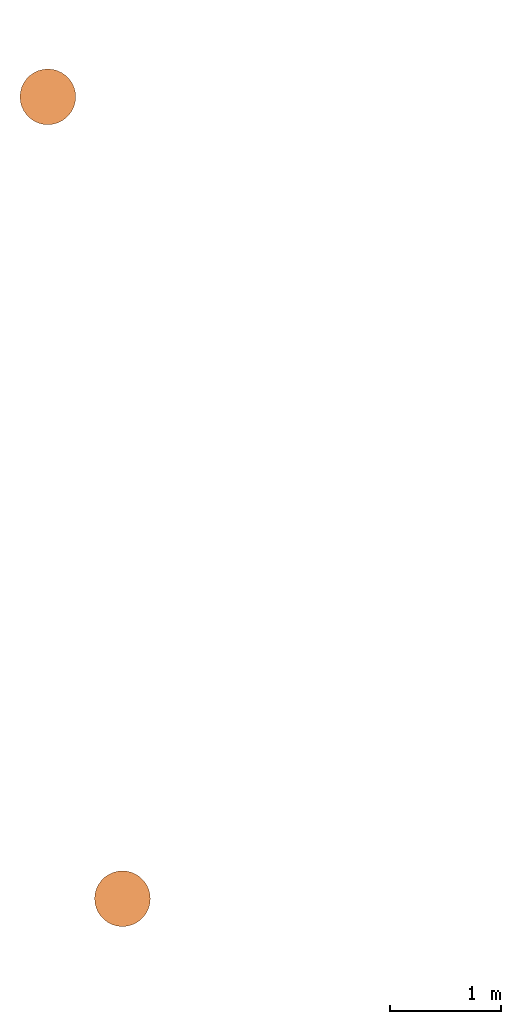
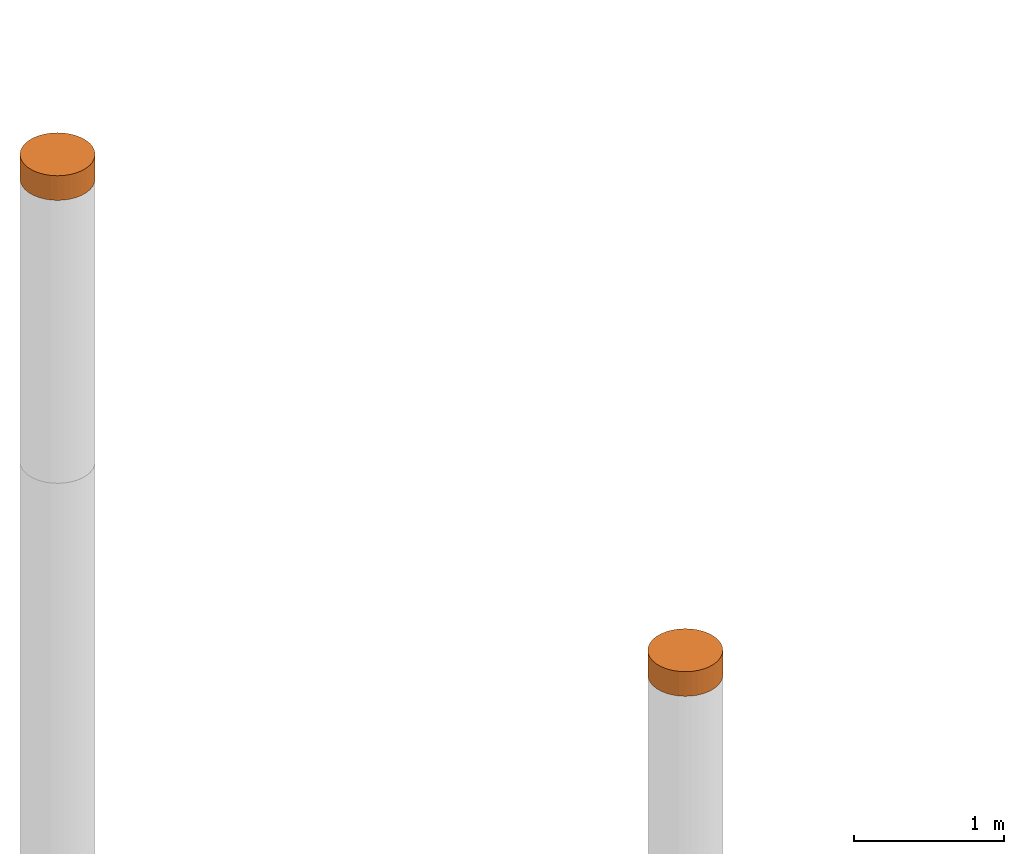
# One storey, part 6 of 8: 2 proxies.
"""IFC4 building model written with IfcOpenShell, lengths in metres."""

from ifc_helpers import new_model, entity, si_unit, converted_unit, frame, origin, place, context, subcontext, project, spatial, faceted_brep, material, element, save


model = new_model("IFC4")

# Units and contexts
model_context = context("Model", 3, precision=1e-05, world=origin())
body_context = subcontext(model_context, "Body", "Model", "MODEL_VIEW")
ifc_project = project(units=[si_unit("LENGTHUNIT", "METRE"), si_unit("AREAUNIT", "SQUARE_METRE"), si_unit("VOLUMEUNIT", "CUBIC_METRE"), converted_unit("PLANEANGLEUNIT", "DEGREE", entity("IfcPlaneAngleMeasure", 0.0174532925199433), si_unit("PLANEANGLEUNIT", "RADIAN"), dimensions=[0, 0, 0, 0, 0, 0, 0])], contexts=[model_context])

# Site, building, storey
site_placement = place(None, origin())
site = spatial("IfcSite", under=ifc_project, at=site_placement, CompositionType="ELEMENT")
building_placement = place(site_placement, origin())
building = spatial("IfcBuilding", under=site, at=building_placement, Name="Demo", CompositionType="ELEMENT")
storey_placement = place(building_placement, origin())
storey = spatial("IfcBuildingStorey", under=building, at=storey_placement, Name="Boden", CompositionType="ELEMENT", Elevation=0.0)

# Proxies
ifc_material_1 = material()
proxy_1_placement = place(storey_placement, frame((2.57, 5.87, -0.1)))
element("IfcBuildingElementProxy", 1, at=proxy_1_placement, inside=storey, material=ifc_material_1, Name="KB-01", PredefinedType="USERDEFINED", context=body_context, shape_type="Brep", body=[
    faceted_brep([(0.4962019382530516, 0.2934120444167338, 0.2), (0.5, 0.25, 0.2), (0.496201938253052, 0.2065879555832671, 0.2), (0.4849231551964772, 0.1644949641685826, 0.2), (0.4665063509461097, 0.125, 0.2), (0.4415111107797448, 0.08930309757836494, 0.2), (0.4106969024216351, 0.05848888922025526, 0.2), (0.375, 0.0334936490538903, 0.2), (0.3355050358314174, 0.01507684480352327, 0.2), (0.2934120444167325, 0.003798061746948406, 0.2), (0.25, 0.0, 0.2), (0.2065879555832676, 0.003798061746948406, 0.2), (0.164494964168583, 0.01507684480352327, 0.2), (0.125, 0.0334936490538903, 0.2), (0.0893030975783654, 0.05848888922025526, 0.2), (0.05848888922025572, 0.08930309757836494, 0.2), (0.0334936490538903, 0.125, 0.2), (0.01507684480352327, 0.1644949641685826, 0.2), (0.003798061746947951, 0.2065879555832671, 0.2), (0.0, 0.25, 0.2), (0.003798061746947951, 0.293412044416732, 0.2), (0.01507684480352282, 0.3355050358314166, 0.2), (0.03349364905388984, 0.375, 0.2), (0.05848888922025526, 0.4106969024216342, 0.2), (0.08930309757836494, 0.4415111107797439, 0.2), (0.1249999999999995, 0.4665063509461097, 0.2), (0.1644949641685821, 0.4849231551964767, 0.2), (0.2065879555832667, 0.4962019382530516, 0.2), (0.2499999999999991, 0.5, 0.2), (0.293412044416732, 0.4962019382530525, 0.2), (0.3355050358314166, 0.4849231551964777, 0.2), (0.3749999999999991, 0.4665063509461097, 0.2), (0.4106969024216342, 0.4415111107797448, 0.2), (0.4415111107797439, 0.410696902421636, 0.2), (0.4665063509461093, 0.3750000000000009, 0.2), (0.4849231551964767, 0.3355050358314184, 0.2), (0.5, 0.25, 0.0), (0.4962019382530516, 0.2934120444167338, 0.0), (0.4849231551964767, 0.3355050358314184, 0.0), (0.4665063509461093, 0.3750000000000009, 0.0), (0.4415111107797439, 0.410696902421636, 0.0), (0.4106969024216342, 0.4415111107797448, 0.0), (0.3749999999999991, 0.4665063509461097, 0.0), (0.3355050358314166, 0.4849231551964777, 0.0), (0.293412044416732, 0.4962019382530525, 0.0), (0.2499999999999991, 0.5, 0.0), (0.2065879555832667, 0.4962019382530516, 0.0), (0.1644949641685821, 0.4849231551964767, 0.0), (0.1249999999999995, 0.4665063509461097, 0.0), (0.08930309757836494, 0.4415111107797439, 0.0), (0.05848888922025526, 0.4106969024216342, 0.0), (0.03349364905388984, 0.3749999999999991, 0.0), (0.01507684480352282, 0.3355050358314166, 0.0), (0.003798061746947951, 0.293412044416732, 0.0), (0.0, 0.25, 0.0), (0.003798061746947951, 0.2065879555832671, 0.0), (0.01507684480352327, 0.1644949641685826, 0.0), (0.0334936490538903, 0.125, 0.0), (0.05848888922025572, 0.08930309757836494, 0.0), (0.0893030975783654, 0.05848888922025526, 0.0), (0.125, 0.0334936490538903, 0.0), (0.164494964168583, 0.01507684480352327, 0.0), (0.2065879555832676, 0.003798061746948406, 0.0), (0.25, 0.0, 0.0), (0.2934120444167325, 0.003798061746948406, 0.0), (0.3355050358314174, 0.01507684480352327, 0.0), (0.375, 0.0334936490538903, 0.0), (0.4106969024216351, 0.05848888922025526, 0.0), (0.4415111107797448, 0.08930309757836494, 0.0), (0.4665063509461097, 0.125, 0.0), (0.4849231551964772, 0.1644949641685826, 0.0), (0.496201938253052, 0.2065879555832671, 0.0), (0.5, 0.25, 0.2), (0.4962019382530516, 0.2934120444167338, 0.2), (0.4962019382530516, 0.2934120444167338, 0.0), (0.5, 0.25, 0.0), (0.496201938253052, 0.2065879555832671, 0.2), (0.5, 0.25, 0.2), (0.5, 0.25, 0.0), (0.496201938253052, 0.2065879555832671, 0.0), (0.4849231551964772, 0.1644949641685826, 0.2), (0.496201938253052, 0.2065879555832671, 0.2), (0.496201938253052, 0.2065879555832671, 0.0), (0.4849231551964772, 0.1644949641685826, 0.0), (0.4665063509461097, 0.125, 0.2), (0.4849231551964772, 0.1644949641685826, 0.2), (0.4849231551964772, 0.1644949641685826, 0.0), (0.4665063509461097, 0.125, 0.0), (0.4415111107797448, 0.08930309757836494, 0.2), (0.4665063509461097, 0.125, 0.2), (0.4665063509461097, 0.125, 0.0), (0.4415111107797448, 0.08930309757836494, 0.0), (0.4106969024216351, 0.05848888922025526, 0.2), (0.4415111107797448, 0.08930309757836494, 0.2), (0.4415111107797448, 0.08930309757836494, 0.0), (0.4106969024216351, 0.05848888922025526, 0.0), (0.375, 0.0334936490538903, 0.2), (0.4106969024216351, 0.05848888922025526, 0.2), (0.4106969024216351, 0.05848888922025526, 0.0), (0.375, 0.0334936490538903, 0.0), (0.3355050358314174, 0.01507684480352327, 0.2), (0.375, 0.0334936490538903, 0.2), (0.375, 0.0334936490538903, 0.0), (0.3355050358314174, 0.01507684480352327, 0.0), (0.2934120444167325, 0.003798061746948406, 0.2), (0.3355050358314174, 0.01507684480352327, 0.2), (0.3355050358314174, 0.01507684480352327, 0.0), (0.2934120444167325, 0.003798061746948406, 0.0), (0.25, 0.0, 0.2), (0.2934120444167325, 0.003798061746948406, 0.2), (0.2934120444167325, 0.003798061746948406, 0.0), (0.25, 0.0, 0.0), (0.2065879555832676, 0.003798061746948406, 0.2), (0.25, 0.0, 0.2), (0.25, 0.0, 0.0), (0.2065879555832676, 0.003798061746948406, 0.0), (0.164494964168583, 0.01507684480352327, 0.2), (0.2065879555832676, 0.003798061746948406, 0.2), (0.2065879555832676, 0.003798061746948406, 0.0), (0.164494964168583, 0.01507684480352327, 0.0), (0.125, 0.0334936490538903, 0.2), (0.164494964168583, 0.01507684480352327, 0.2), (0.164494964168583, 0.01507684480352327, 0.0), (0.125, 0.0334936490538903, 0.0), (0.0893030975783654, 0.05848888922025526, 0.2), (0.125, 0.0334936490538903, 0.2), (0.125, 0.0334936490538903, 0.0), (0.0893030975783654, 0.05848888922025526, 0.0), (0.05848888922025572, 0.08930309757836494, 0.2), (0.0893030975783654, 0.05848888922025526, 0.2), (0.0893030975783654, 0.05848888922025526, 0.0), (0.05848888922025572, 0.08930309757836494, 0.0), (0.0334936490538903, 0.125, 0.2), (0.05848888922025572, 0.08930309757836494, 0.2), (0.05848888922025572, 0.08930309757836494, 0.0), (0.0334936490538903, 0.125, 0.0), (0.01507684480352327, 0.1644949641685826, 0.2), (0.0334936490538903, 0.125, 0.2), (0.0334936490538903, 0.125, 0.0), (0.01507684480352327, 0.1644949641685826, 0.0), (0.003798061746947951, 0.2065879555832671, 0.2), (0.01507684480352327, 0.1644949641685826, 0.2), (0.01507684480352327, 0.1644949641685826, 0.0), (0.003798061746947951, 0.2065879555832671, 0.0), (0.0, 0.25, 0.2), (0.003798061746947951, 0.2065879555832671, 0.2), (0.003798061746947951, 0.2065879555832671, 0.0), (0.0, 0.25, 0.0), (0.003798061746947951, 0.293412044416732, 0.2), (0.0, 0.25, 0.2), (0.0, 0.25, 0.0), (0.003798061746947951, 0.293412044416732, 0.0), (0.01507684480352282, 0.3355050358314166, 0.2), (0.003798061746947951, 0.293412044416732, 0.2), (0.003798061746947951, 0.293412044416732, 0.0), (0.01507684480352282, 0.3355050358314166, 0.0), (0.03349364905388984, 0.375, 0.2), (0.01507684480352282, 0.3355050358314166, 0.2), (0.01507684480352282, 0.3355050358314166, 0.0), (0.03349364905388984, 0.3749999999999991, 0.0), (0.05848888922025526, 0.4106969024216342, 0.2), (0.03349364905388984, 0.375, 0.2), (0.03349364905388984, 0.3749999999999991, 0.0), (0.05848888922025526, 0.4106969024216342, 0.0), (0.08930309757836494, 0.4415111107797439, 0.2), (0.05848888922025526, 0.4106969024216342, 0.2), (0.05848888922025526, 0.4106969024216342, 0.0), (0.08930309757836494, 0.4415111107797439, 0.0), (0.1249999999999995, 0.4665063509461097, 0.2), (0.08930309757836494, 0.4415111107797439, 0.2), (0.08930309757836494, 0.4415111107797439, 0.0), (0.1249999999999995, 0.4665063509461097, 0.0), (0.1644949641685821, 0.4849231551964767, 0.2), (0.1249999999999995, 0.4665063509461097, 0.2), (0.1249999999999995, 0.4665063509461097, 0.0), (0.1644949641685821, 0.4849231551964767, 0.0), (0.2065879555832667, 0.4962019382530516, 0.2), (0.1644949641685821, 0.4849231551964767, 0.2), (0.1644949641685821, 0.4849231551964767, 0.0), (0.2065879555832667, 0.4962019382530516, 0.0), (0.2499999999999991, 0.5, 0.2), (0.2065879555832667, 0.4962019382530516, 0.2), (0.2065879555832667, 0.4962019382530516, 0.0), (0.2499999999999991, 0.5, 0.0), (0.293412044416732, 0.4962019382530525, 0.2), (0.2499999999999991, 0.5, 0.2), (0.2499999999999991, 0.5, 0.0), (0.293412044416732, 0.4962019382530525, 0.0), (0.3355050358314166, 0.4849231551964777, 0.2), (0.293412044416732, 0.4962019382530525, 0.2), (0.293412044416732, 0.4962019382530525, 0.0), (0.3355050358314166, 0.4849231551964777, 0.0), (0.3749999999999991, 0.4665063509461097, 0.2), (0.3355050358314166, 0.4849231551964777, 0.2), (0.3355050358314166, 0.4849231551964777, 0.0), (0.3749999999999991, 0.4665063509461097, 0.0), (0.4106969024216342, 0.4415111107797448, 0.2), (0.3749999999999991, 0.4665063509461097, 0.2), (0.3749999999999991, 0.4665063509461097, 0.0), (0.4106969024216342, 0.4415111107797448, 0.0), (0.4415111107797439, 0.410696902421636, 0.2), (0.4106969024216342, 0.4415111107797448, 0.2), (0.4106969024216342, 0.4415111107797448, 0.0), (0.4415111107797439, 0.410696902421636, 0.0), (0.4665063509461093, 0.3750000000000009, 0.2), (0.4415111107797439, 0.410696902421636, 0.2), (0.4415111107797439, 0.410696902421636, 0.0), (0.4665063509461093, 0.3750000000000009, 0.0), (0.4849231551964767, 0.3355050358314184, 0.2), (0.4665063509461093, 0.3750000000000009, 0.2), (0.4665063509461093, 0.3750000000000009, 0.0), (0.4849231551964767, 0.3355050358314184, 0.0), (0.4962019382530516, 0.2934120444167338, 0.2), (0.4849231551964767, 0.3355050358314184, 0.2), (0.4849231551964767, 0.3355050358314184, 0.0), (0.4962019382530516, 0.2934120444167338, 0.0)], [[[0, 1, 2, 3, 4, 5, 6, 7, 8, 9, 10, 11, 12, 13, 14, 15, 16, 17, 18, 19, 20, 21, 22, 23, 24, 25, 26, 27, 28, 29, 30, 31, 32, 33, 34, 35]], [[36, 37, 38, 39, 40, 41, 42, 43, 44, 45, 46, 47, 48, 49, 50, 51, 52, 53, 54, 55, 56, 57, 58, 59, 60, 61, 62, 63, 64, 65, 66, 67, 68, 69, 70, 71]], [[72, 73, 74, 75]], [[76, 77, 78, 79]], [[80, 81, 82, 83]], [[84, 85, 86, 87]], [[88, 89, 90, 91]], [[92, 93, 94, 95]], [[96, 97, 98, 99]], [[100, 101, 102, 103]], [[104, 105, 106, 107]], [[108, 109, 110, 111]], [[112, 113, 114, 115]], [[116, 117, 118, 119]], [[120, 121, 122, 123]], [[124, 125, 126, 127]], [[128, 129, 130, 131]], [[132, 133, 134, 135]], [[136, 137, 138, 139]], [[140, 141, 142, 143]], [[144, 145, 146, 147]], [[148, 149, 150, 151]], [[152, 153, 154, 155]], [[156, 157, 158, 159]], [[160, 161, 162, 163]], [[164, 165, 166, 167]], [[168, 169, 170, 171]], [[172, 173, 174, 175]], [[176, 177, 178, 179]], [[180, 181, 182, 183]], [[184, 185, 186, 187]], [[188, 189, 190, 191]], [[192, 193, 194, 195]], [[196, 197, 198, 199]], [[200, 201, 202, 203]], [[204, 205, 206, 207]], [[208, 209, 210, 211]], [[212, 213, 214, 215]]], orient=[[False], [False], [False], [False], [False], [False], [False], [False], [False], [False], [False], [False], [False], [False], [False], [False], [False], [False], [False], [False], [False], [False], [False], [False], [False], [False], [False], [False], [False], [False], [False], [False], [False], [False], [False], [False], [False], [False]]),
])
ifc_material_2 = material()
proxy_2_placement = place(storey_placement, frame((1.9, 13.07, -0.2)))
element("IfcBuildingElementProxy", 2, at=proxy_2_placement, inside=storey, material=ifc_material_2, Name="KB-04", PredefinedType="USERDEFINED", context=body_context, shape_type="Brep", body=[
    faceted_brep([(0.4962019382530516, 0.2934120444167329, 0.2), (0.5, 0.25, 0.2), (0.496201938253052, 0.2065879555832671, 0.2), (0.4849231551964772, 0.1644949641685835, 0.2), (0.4665063509461097, 0.125, 0.2), (0.4415111107797448, 0.08930309757836585, 0.2), (0.4106969024216351, 0.05848888922025617, 0.2), (0.375, 0.0334936490538912, 0.2), (0.3355050358314174, 0.01507684480352327, 0.2), (0.2934120444167325, 0.003798061746947497, 0.2), (0.25, 0.0, 0.2), (0.2065879555832676, 0.003798061746947497, 0.2), (0.164494964168583, 0.01507684480352327, 0.2), (0.125, 0.03349364905388939, 0.2), (0.08930309757836517, 0.05848888922025617, 0.2), (0.05848888922025572, 0.08930309757836585, 0.2), (0.03349364905389052, 0.125, 0.2), (0.01507684480352305, 0.1644949641685835, 0.2), (0.003798061746947951, 0.2065879555832671, 0.2), (0.0, 0.25, 0.2), (0.003798061746947951, 0.2934120444167329, 0.2), (0.01507684480352282, 0.3355050358314166, 0.2), (0.03349364905389007, 0.375, 0.2), (0.05848888922025503, 0.4106969024216342, 0.2), (0.08930309757836472, 0.4415111107797439, 0.2), (0.1249999999999995, 0.4665063509461088, 0.2), (0.1644949641685821, 0.4849231551964767, 0.2), (0.2065879555832667, 0.4962019382530525, 0.2), (0.2499999999999991, 0.5, 0.2), (0.293412044416732, 0.4962019382530525, 0.2), (0.3355050358314166, 0.4849231551964767, 0.2), (0.3749999999999991, 0.4665063509461107, 0.2), (0.4106969024216342, 0.4415111107797456, 0.2), (0.4415111107797439, 0.410696902421636, 0.2), (0.4665063509461093, 0.375, 0.2), (0.4849231551964767, 0.3355050358314184, 0.2), (0.5, 0.25, 0.0), (0.4962019382530516, 0.2934120444167329, 0.0), (0.4849231551964767, 0.3355050358314184, 0.0), (0.4665063509461093, 0.375, 0.0), (0.4415111107797439, 0.410696902421636, 0.0), (0.4106969024216342, 0.4415111107797456, 0.0), (0.3749999999999991, 0.4665063509461107, 0.0), (0.3355050358314166, 0.4849231551964767, 0.0), (0.293412044416732, 0.4962019382530525, 0.0), (0.2499999999999991, 0.5, 0.0), (0.2065879555832667, 0.4962019382530525, 0.0), (0.1644949641685821, 0.4849231551964767, 0.0), (0.1249999999999995, 0.4665063509461088, 0.0), (0.08930309757836472, 0.4415111107797439, 0.0), (0.05848888922025503, 0.4106969024216342, 0.0), (0.03349364905389007, 0.375, 0.0), (0.01507684480352282, 0.3355050358314166, 0.0), (0.003798061746947951, 0.2934120444167329, 0.0), (0.0, 0.25, 0.0), (0.003798061746947951, 0.2065879555832671, 0.0), (0.01507684480352305, 0.1644949641685816, 0.0), (0.03349364905389052, 0.125, 0.0), (0.05848888922025572, 0.08930309757836585, 0.0), (0.08930309757836517, 0.05848888922025617, 0.0), (0.125, 0.03349364905388939, 0.0), (0.164494964168583, 0.01507684480352327, 0.0), (0.2065879555832676, 0.003798061746947497, 0.0), (0.25, 0.0, 0.0), (0.2934120444167325, 0.003798061746947497, 0.0), (0.3355050358314174, 0.01507684480352327, 0.0), (0.375, 0.0334936490538912, 0.0), (0.4106969024216351, 0.05848888922025617, 0.0), (0.4415111107797448, 0.08930309757836585, 0.0), (0.4665063509461097, 0.125, 0.0), (0.4849231551964772, 0.1644949641685835, 0.0), (0.496201938253052, 0.2065879555832671, 0.0), (0.5, 0.25, 0.2), (0.4962019382530516, 0.2934120444167329, 0.2), (0.4962019382530516, 0.2934120444167329, 0.0), (0.5, 0.25, 0.0), (0.496201938253052, 0.2065879555832671, 0.2), (0.5, 0.25, 0.2), (0.5, 0.25, 0.0), (0.496201938253052, 0.2065879555832671, 0.0), (0.4849231551964772, 0.1644949641685835, 0.2), (0.496201938253052, 0.2065879555832671, 0.2), (0.496201938253052, 0.2065879555832671, 0.0), (0.4849231551964772, 0.1644949641685835, 0.0), (0.4665063509461097, 0.125, 0.2), (0.4849231551964772, 0.1644949641685835, 0.2), (0.4849231551964772, 0.1644949641685835, 0.0), (0.4665063509461097, 0.125, 0.0), (0.4415111107797448, 0.08930309757836585, 0.2), (0.4665063509461097, 0.125, 0.2), (0.4665063509461097, 0.125, 0.0), (0.4415111107797448, 0.08930309757836585, 0.0), (0.4106969024216351, 0.05848888922025617, 0.2), (0.4415111107797448, 0.08930309757836585, 0.2), (0.4415111107797448, 0.08930309757836585, 0.0), (0.4106969024216351, 0.05848888922025617, 0.0), (0.375, 0.0334936490538912, 0.2), (0.4106969024216351, 0.05848888922025617, 0.2), (0.4106969024216351, 0.05848888922025617, 0.0), (0.375, 0.0334936490538912, 0.0), (0.3355050358314174, 0.01507684480352327, 0.2), (0.375, 0.0334936490538912, 0.2), (0.375, 0.0334936490538912, 0.0), (0.3355050358314174, 0.01507684480352327, 0.0), (0.2934120444167325, 0.003798061746947497, 0.2), (0.3355050358314174, 0.01507684480352327, 0.2), (0.3355050358314174, 0.01507684480352327, 0.0), (0.2934120444167325, 0.003798061746947497, 0.0), (0.25, 0.0, 0.2), (0.2934120444167325, 0.003798061746947497, 0.2), (0.2934120444167325, 0.003798061746947497, 0.0), (0.25, 0.0, 0.0), (0.2065879555832676, 0.003798061746947497, 0.2), (0.25, 0.0, 0.2), (0.25, 0.0, 0.0), (0.2065879555832676, 0.003798061746947497, 0.0), (0.164494964168583, 0.01507684480352327, 0.2), (0.2065879555832676, 0.003798061746947497, 0.2), (0.2065879555832676, 0.003798061746947497, 0.0), (0.164494964168583, 0.01507684480352327, 0.0), (0.125, 0.03349364905388939, 0.2), (0.164494964168583, 0.01507684480352327, 0.2), (0.164494964168583, 0.01507684480352327, 0.0), (0.125, 0.03349364905388939, 0.0), (0.08930309757836517, 0.05848888922025617, 0.2), (0.125, 0.03349364905388939, 0.2), (0.125, 0.03349364905388939, 0.0), (0.08930309757836517, 0.05848888922025617, 0.0), (0.05848888922025572, 0.08930309757836585, 0.2), (0.08930309757836517, 0.05848888922025617, 0.2), (0.08930309757836517, 0.05848888922025617, 0.0), (0.05848888922025572, 0.08930309757836585, 0.0), (0.03349364905389052, 0.125, 0.2), (0.05848888922025572, 0.08930309757836585, 0.2), (0.05848888922025572, 0.08930309757836585, 0.0), (0.03349364905389052, 0.125, 0.0), (0.01507684480352305, 0.1644949641685835, 0.2), (0.03349364905389052, 0.125, 0.2), (0.03349364905389052, 0.125, 0.0), (0.01507684480352305, 0.1644949641685816, 0.0), (0.003798061746947951, 0.2065879555832671, 0.2), (0.01507684480352305, 0.1644949641685835, 0.2), (0.01507684480352305, 0.1644949641685816, 0.0), (0.003798061746947951, 0.2065879555832671, 0.0), (0.0, 0.25, 0.2), (0.003798061746947951, 0.2065879555832671, 0.2), (0.003798061746947951, 0.2065879555832671, 0.0), (0.0, 0.25, 0.0), (0.003798061746947951, 0.2934120444167329, 0.2), (0.0, 0.25, 0.2), (0.0, 0.25, 0.0), (0.003798061746947951, 0.2934120444167329, 0.0), (0.01507684480352282, 0.3355050358314166, 0.2), (0.003798061746947951, 0.2934120444167329, 0.2), (0.003798061746947951, 0.2934120444167329, 0.0), (0.01507684480352282, 0.3355050358314166, 0.0), (0.03349364905389007, 0.375, 0.2), (0.01507684480352282, 0.3355050358314166, 0.2), (0.01507684480352282, 0.3355050358314166, 0.0), (0.03349364905389007, 0.375, 0.0), (0.05848888922025503, 0.4106969024216342, 0.2), (0.03349364905389007, 0.375, 0.2), (0.03349364905389007, 0.375, 0.0), (0.05848888922025503, 0.4106969024216342, 0.0), (0.08930309757836472, 0.4415111107797439, 0.2), (0.05848888922025503, 0.4106969024216342, 0.2), (0.05848888922025503, 0.4106969024216342, 0.0), (0.08930309757836472, 0.4415111107797439, 0.0), (0.1249999999999995, 0.4665063509461088, 0.2), (0.08930309757836472, 0.4415111107797439, 0.2), (0.08930309757836472, 0.4415111107797439, 0.0), (0.1249999999999995, 0.4665063509461088, 0.0), (0.1644949641685821, 0.4849231551964767, 0.2), (0.1249999999999995, 0.4665063509461088, 0.2), (0.1249999999999995, 0.4665063509461088, 0.0), (0.1644949641685821, 0.4849231551964767, 0.0), (0.2065879555832667, 0.4962019382530525, 0.2), (0.1644949641685821, 0.4849231551964767, 0.2), (0.1644949641685821, 0.4849231551964767, 0.0), (0.2065879555832667, 0.4962019382530525, 0.0), (0.2499999999999991, 0.5, 0.2), (0.2065879555832667, 0.4962019382530525, 0.2), (0.2065879555832667, 0.4962019382530525, 0.0), (0.2499999999999991, 0.5, 0.0), (0.293412044416732, 0.4962019382530525, 0.2), (0.2499999999999991, 0.5, 0.2), (0.2499999999999991, 0.5, 0.0), (0.293412044416732, 0.4962019382530525, 0.0), (0.3355050358314166, 0.4849231551964767, 0.2), (0.293412044416732, 0.4962019382530525, 0.2), (0.293412044416732, 0.4962019382530525, 0.0), (0.3355050358314166, 0.4849231551964767, 0.0), (0.3749999999999991, 0.4665063509461107, 0.2), (0.3355050358314166, 0.4849231551964767, 0.2), (0.3355050358314166, 0.4849231551964767, 0.0), (0.3749999999999991, 0.4665063509461107, 0.0), (0.4106969024216342, 0.4415111107797456, 0.2), (0.3749999999999991, 0.4665063509461107, 0.2), (0.3749999999999991, 0.4665063509461107, 0.0), (0.4106969024216342, 0.4415111107797456, 0.0), (0.4415111107797439, 0.410696902421636, 0.2), (0.4106969024216342, 0.4415111107797456, 0.2), (0.4106969024216342, 0.4415111107797456, 0.0), (0.4415111107797439, 0.410696902421636, 0.0), (0.4665063509461093, 0.375, 0.2), (0.4415111107797439, 0.410696902421636, 0.2), (0.4415111107797439, 0.410696902421636, 0.0), (0.4665063509461093, 0.375, 0.0), (0.4849231551964767, 0.3355050358314184, 0.2), (0.4665063509461093, 0.375, 0.2), (0.4665063509461093, 0.375, 0.0), (0.4849231551964767, 0.3355050358314184, 0.0), (0.4962019382530516, 0.2934120444167329, 0.2), (0.4849231551964767, 0.3355050358314184, 0.2), (0.4849231551964767, 0.3355050358314184, 0.0), (0.4962019382530516, 0.2934120444167329, 0.0)], [[[0, 1, 2, 3, 4, 5, 6, 7, 8, 9, 10, 11, 12, 13, 14, 15, 16, 17, 18, 19, 20, 21, 22, 23, 24, 25, 26, 27, 28, 29, 30, 31, 32, 33, 34, 35]], [[36, 37, 38, 39, 40, 41, 42, 43, 44, 45, 46, 47, 48, 49, 50, 51, 52, 53, 54, 55, 56, 57, 58, 59, 60, 61, 62, 63, 64, 65, 66, 67, 68, 69, 70, 71]], [[72, 73, 74, 75]], [[76, 77, 78, 79]], [[80, 81, 82, 83]], [[84, 85, 86, 87]], [[88, 89, 90, 91]], [[92, 93, 94, 95]], [[96, 97, 98, 99]], [[100, 101, 102, 103]], [[104, 105, 106, 107]], [[108, 109, 110, 111]], [[112, 113, 114, 115]], [[116, 117, 118, 119]], [[120, 121, 122, 123]], [[124, 125, 126, 127]], [[128, 129, 130, 131]], [[132, 133, 134, 135]], [[136, 137, 138, 139]], [[140, 141, 142, 143]], [[144, 145, 146, 147]], [[148, 149, 150, 151]], [[152, 153, 154, 155]], [[156, 157, 158, 159]], [[160, 161, 162, 163]], [[164, 165, 166, 167]], [[168, 169, 170, 171]], [[172, 173, 174, 175]], [[176, 177, 178, 179]], [[180, 181, 182, 183]], [[184, 185, 186, 187]], [[188, 189, 190, 191]], [[192, 193, 194, 195]], [[196, 197, 198, 199]], [[200, 201, 202, 203]], [[204, 205, 206, 207]], [[208, 209, 210, 211]], [[212, 213, 214, 215]]], orient=[[False], [False], [False], [False], [False], [False], [False], [False], [False], [False], [False], [False], [False], [False], [False], [False], [False], [False], [False], [False], [False], [False], [False], [False], [False], [False], [False], [False], [False], [False], [False], [False], [False], [False], [False], [False], [False], [False]]),
])

save(model, "model.ifc")
